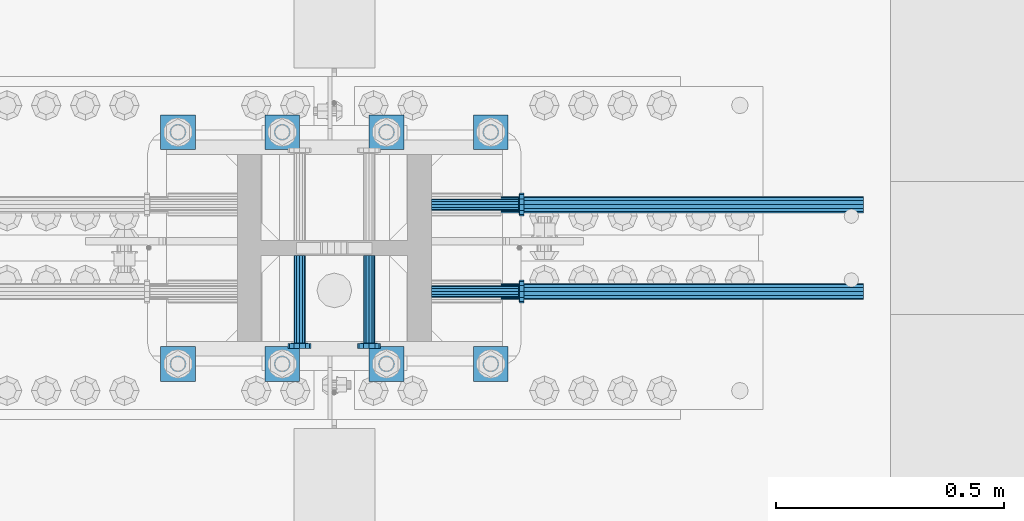
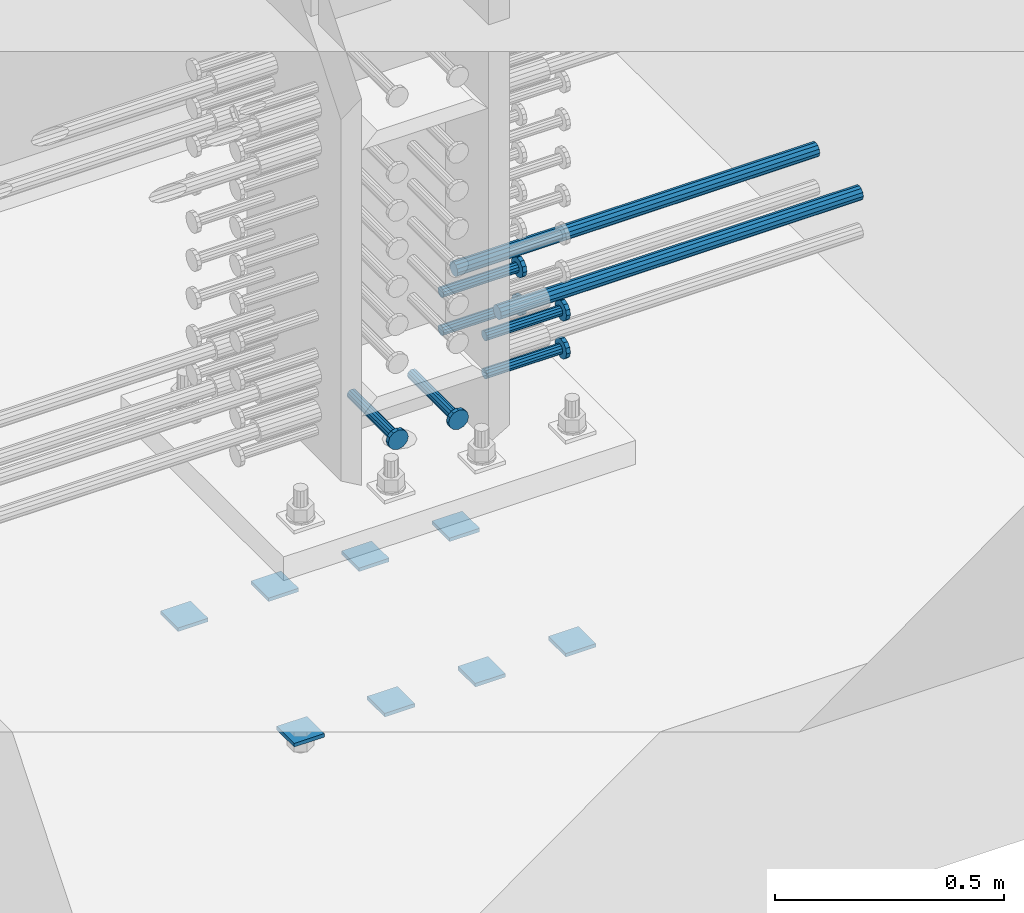
# One storey, part 1223 of 1763: 16 beams, 4 elements without a shape of their own.
"""IFC2X3 building model written with IfcOpenShell, lengths in millimetres."""

from ifc_helpers import new_model, si_unit, frame, origin_with_axes, place, context, subcontext, project, spatial, faceted_brep, material, type_object, element, aggregate, save


model = new_model("IFC2X3")

# Units and contexts
model_context = context("Model", 3, precision=1e-05, world=origin_with_axes())
body_context = subcontext(model_context, "Body", "Model", "MODEL_VIEW")
ifc_project = project(units=[si_unit("LENGTHUNIT", "METRE", prefix="MILLI"), si_unit("AREAUNIT", "SQUARE_METRE"), si_unit("VOLUMEUNIT", "CUBIC_METRE"), si_unit("MASSUNIT", "GRAM", prefix="KILO"), si_unit("TIMEUNIT", "SECOND"), si_unit("PLANEANGLEUNIT", "RADIAN"), si_unit("SOLIDANGLEUNIT", "STERADIAN"), si_unit("THERMODYNAMICTEMPERATUREUNIT", "DEGREE_CELSIUS"), si_unit("LUMINOUSINTENSITYUNIT", "LUMEN")], contexts=[model_context])

# Site, building, storey
site_placement = place(None, origin_with_axes())
site = spatial("IfcSite", under=ifc_project, at=site_placement, CompositionType="ELEMENT")
building_placement = place(site_placement, origin_with_axes())
building = spatial("IfcBuilding", under=site, at=building_placement, Name="Undefined", CompositionType="ELEMENT")
storey_placement = place(building_placement, origin_with_axes())
storey = spatial("IfcBuildingStorey", under=building, at=storey_placement, Name="Undefined", CompositionType="ELEMENT", Elevation=0.0)

# Assembly, beams
assembly_1_placement = place(storey_placement, origin_with_axes())
assembly_1 = element("IfcElementAssembly", 1, at=assembly_1_placement, inside=storey, Name="TEMPLATE", AssemblyPlace="NOTDEFINED", PredefinedType="RIGID_FRAME")
ifc_material_1 = material(Name="STEEL/A36")
beam_type_1 = type_object("IfcBeamType", PredefinedType="NOTDEFINED")
beam_1_placement = place(assembly_1_placement, frame((-61213.4372736986, 203.200000000006, 3348.0375), z_axis=(0.0, 1.0, 0.0), x_axis=(-1.0, 0.0, 0.0)))
beam_1 = element("IfcBeam", 2, at=beam_1_placement, type_object=beam_type_1, material=ifc_material_1, Name="WASHER PLATE", context=body_context, shape_type="Brep", body=[
    faceted_brep([(0.0, 4.76249999999709, -38.1000000000004), (0.0, 4.76249999999709, 38.1000000000004), (76.2000000000007, 4.76249999999982, 38.0999999999985), (76.2000000000007, 4.76249999999982, -38.0999999999985), (0.0, -4.76249999999709, 38.1000000000004), (76.2000000000007, -4.76249999999982, 38.0999999999985), (0.0, -4.76249999999709, -38.1000000000004), (76.2000000000007, -4.76249999999982, -38.0999999999985)], [[[0, 1, 2, 3]], [[1, 4, 5, 2]], [[4, 6, 7, 5]], [[6, 0, 3, 7]], [[5, 7, 3, 2]], [[6, 4, 1, 0]]]),
])
beam_2_placement = place(assembly_1_placement, frame((-61213.4372736986, 711.200000000006, 3348.0375), z_axis=(0.0, 1.0, 0.0), x_axis=(-1.0, 0.0, 0.0)))
beam_2 = element("IfcBeam", 3, at=beam_2_placement, type_object=beam_type_1, material=ifc_material_1, Name="WASHER PLATE", context=body_context, shape_type="Brep", body=[
    faceted_brep([(0.0, 4.76249999999709, -38.1000000000004), (0.0, 4.76249999999709, 38.1000000000004), (76.2000000000007, 4.76249999999982, 38.0999999999985), (76.2000000000007, 4.76249999999982, -38.0999999999985), (0.0, -4.76249999999709, 38.1000000000004), (76.2000000000007, -4.76249999999982, 38.0999999999985), (0.0, -4.76249999999709, -38.1000000000004), (76.2000000000007, -4.76249999999982, -38.0999999999985)], [[[0, 1, 2, 3]], [[1, 4, 5, 2]], [[4, 6, 7, 5]], [[6, 0, 3, 7]], [[5, 7, 3, 2]], [[6, 4, 1, 0]]]),
])
beam_3_placement = place(assembly_1_placement, frame((-61442.0372736986, 203.200000000006, 3348.0375), z_axis=(0.0, 1.0, 0.0), x_axis=(-1.0, 0.0, 0.0)))
beam_3 = element("IfcBeam", 4, at=beam_3_placement, type_object=beam_type_1, material=ifc_material_1, Name="WASHER PLATE", context=body_context, shape_type="Brep", body=[
    faceted_brep([(0.0, 4.76249999999709, -38.1000000000004), (0.0, 4.76249999999709, 38.1000000000004), (76.2000000000007, 4.76249999999982, 38.0999999999985), (76.2000000000007, 4.76249999999982, -38.0999999999985), (0.0, -4.76249999999709, 38.1000000000004), (76.2000000000007, -4.76249999999982, 38.0999999999985), (0.0, -4.76249999999709, -38.1000000000004), (76.2000000000007, -4.76249999999982, -38.0999999999985)], [[[0, 1, 2, 3]], [[1, 4, 5, 2]], [[4, 6, 7, 5]], [[6, 0, 3, 7]], [[5, 7, 3, 2]], [[6, 4, 1, 0]]]),
])
beam_4_placement = place(assembly_1_placement, frame((-61442.0372736986, 711.200000000006, 3348.0375), z_axis=(0.0, 1.0, 0.0), x_axis=(-1.0, 0.0, 0.0)))
beam_4 = element("IfcBeam", 5, at=beam_4_placement, type_object=beam_type_1, material=ifc_material_1, Name="WASHER PLATE", context=body_context, shape_type="Brep", body=[
    faceted_brep([(0.0, 4.76249999999709, -38.1000000000004), (0.0, 4.76249999999709, 38.1000000000004), (76.2000000000007, 4.76249999999982, 38.0999999999985), (76.2000000000007, 4.76249999999982, -38.0999999999985), (0.0, -4.76249999999709, 38.1000000000004), (76.2000000000007, -4.76249999999982, 38.0999999999985), (0.0, -4.76249999999709, -38.1000000000004), (76.2000000000007, -4.76249999999982, -38.0999999999985)], [[[0, 1, 2, 3]], [[1, 4, 5, 2]], [[4, 6, 7, 5]], [[6, 0, 3, 7]], [[5, 7, 3, 2]], [[6, 4, 1, 0]]]),
])
beam_5_placement = place(assembly_1_placement, frame((-61670.6372736986, 203.200000000006, 3348.0375), z_axis=(0.0, 1.0, 0.0), x_axis=(-1.0, 0.0, 0.0)))
beam_5 = element("IfcBeam", 6, at=beam_5_placement, type_object=beam_type_1, material=ifc_material_1, Name="WASHER PLATE", context=body_context, shape_type="Brep", body=[
    faceted_brep([(0.0, 4.76249999999709, -38.1000000000004), (0.0, 4.76249999999709, 38.1000000000004), (76.2000000000007, 4.76249999999982, 38.0999999999985), (76.2000000000007, 4.76249999999982, -38.0999999999985), (0.0, -4.76249999999709, 38.1000000000004), (76.2000000000007, -4.76249999999982, 38.0999999999985), (0.0, -4.76249999999709, -38.1000000000004), (76.2000000000007, -4.76249999999982, -38.0999999999985)], [[[0, 1, 2, 3]], [[1, 4, 5, 2]], [[4, 6, 7, 5]], [[6, 0, 3, 7]], [[5, 7, 3, 2]], [[6, 4, 1, 0]]]),
])
beam_6_placement = place(assembly_1_placement, frame((-61670.6372736986, 711.200000000006, 3348.0375), z_axis=(0.0, 1.0, 0.0), x_axis=(-1.0, 0.0, 0.0)))
beam_6 = element("IfcBeam", 7, at=beam_6_placement, type_object=beam_type_1, material=ifc_material_1, Name="WASHER PLATE", context=body_context, shape_type="Brep", body=[
    faceted_brep([(0.0, 4.76249999999709, -38.1000000000004), (0.0, 4.76249999999709, 38.1000000000004), (76.2000000000007, 4.76249999999982, 38.0999999999985), (76.2000000000007, 4.76249999999982, -38.0999999999985), (0.0, -4.76249999999709, 38.1000000000004), (76.2000000000007, -4.76249999999982, 38.0999999999985), (0.0, -4.76249999999709, -38.1000000000004), (76.2000000000007, -4.76249999999982, -38.0999999999985)], [[[0, 1, 2, 3]], [[1, 4, 5, 2]], [[4, 6, 7, 5]], [[6, 0, 3, 7]], [[5, 7, 3, 2]], [[6, 4, 1, 0]]]),
])
beam_7_placement = place(assembly_1_placement, frame((-61899.2372736986, 203.200000000006, 3348.0375), z_axis=(0.0, 1.0, 0.0), x_axis=(-1.0, 0.0, 0.0)))
beam_7 = element("IfcBeam", 8, at=beam_7_placement, type_object=beam_type_1, material=ifc_material_1, Name="WASHER PLATE", context=body_context, shape_type="Brep", body=[
    faceted_brep([(0.0, 4.76249999999709, -38.1000000000004), (0.0, 4.76249999999709, 38.1000000000004), (76.2000000000007, 4.76249999999982, 38.0999999999985), (76.2000000000007, 4.76249999999982, -38.0999999999985), (0.0, -4.76249999999709, 38.1000000000004), (76.2000000000007, -4.76249999999982, 38.0999999999985), (0.0, -4.76249999999709, -38.1000000000004), (76.2000000000007, -4.76249999999982, -38.0999999999985)], [[[0, 1, 2, 3]], [[1, 4, 5, 2]], [[4, 6, 7, 5]], [[6, 0, 3, 7]], [[5, 7, 3, 2]], [[6, 4, 1, 0]]]),
])
beam_8_placement = place(assembly_1_placement, frame((-61899.2372736986, 711.200000000006, 3348.0375), z_axis=(0.0, 1.0, 0.0), x_axis=(-1.0, 0.0, 0.0)))
beam_8 = element("IfcBeam", 9, at=beam_8_placement, type_object=beam_type_1, material=ifc_material_1, Name="WASHER PLATE", context=body_context, shape_type="Brep", body=[
    faceted_brep([(0.0, 4.76249999999709, -38.1000000000004), (0.0, 4.76249999999709, 38.1000000000004), (76.2000000000007, 4.76249999999982, 38.0999999999985), (76.2000000000007, 4.76249999999982, -38.0999999999985), (0.0, -4.76249999999709, 38.1000000000004), (76.2000000000007, -4.76249999999982, 38.0999999999985), (0.0, -4.76249999999709, -38.1000000000004), (76.2000000000007, -4.76249999999982, -38.0999999999985)], [[[0, 1, 2, 3]], [[1, 4, 5, 2]], [[4, 6, 7, 5]], [[6, 0, 3, 7]], [[5, 7, 3, 2]], [[6, 4, 1, 0]]]),
])
aggregate(assembly_1, [beam_1, beam_2, beam_3, beam_4, beam_5, beam_6, beam_7, beam_8])

# Assembly, beam
assembly_2_placement = place(storey_placement, origin_with_axes())
assembly_2 = element("IfcElementAssembly", 10, at=assembly_2_placement, inside=storey, Name="REBAR", AssemblyPlace="NOTDEFINED", PredefinedType="RIGID_FRAME")
ifc_material_2 = material(Name="STEEL/A706-GR.80")
beam_type_2 = type_object("IfcBeamType", Name="#11 REBAR", PredefinedType="NOTDEFINED")
beam_9_placement = place(assembly_2_placement, frame((-61348.946286658, 361.949999998906, 4165.60000000003), z_axis=(0.0, 0.0, 1.0), x_axis=(1.0, 0.0, 0.0)))
beam_9 = element("IfcBeam", 11, at=beam_9_placement, type_object=beam_type_2, material=ifc_material_2, Name="REBAR", ObjectType="#11 REBAR", context=body_context, shape_type="Brep", body=[
    faceted_brep([(0.0, -17.9069999999992, 0.0), (0.0, -15.507916905568, -8.95349999999962), (914.400000001086, -15.507916905568, -8.95349999999962), (914.400000001086, -17.9069999999992, 0.0), (0.0, -8.95349999999962, -15.507916905568), (914.400000001086, -8.95349999999962, -15.507916905568), (0.0, 0.0, -17.9070000000002), (914.400000001086, 0.0, -17.9070000000002), (0.0, 8.95349999999962, -15.507916905568), (914.400000001086, 8.95349999999962, -15.507916905568), (0.0, 15.507916905568, -8.95349999999962), (914.400000001086, 15.507916905568, -8.95349999999962), (0.0, 17.9069999999992, 0.0), (914.400000001086, 17.9069999999992, 0.0), (0.0, 15.507916905568, 8.95349999999962), (914.400000001086, 15.507916905568, 8.95349999999962), (0.0, 8.95349999999962, 15.507916905568), (914.400000001086, 8.95349999999962, 15.507916905568), (0.0, 0.0, 17.9070000000002), (914.400000001086, 0.0, 17.9070000000002), (0.0, -8.95349999999962, 15.507916905568), (914.400000001086, -8.95349999999962, 15.507916905568), (0.0, -15.507916905568, 8.95349999999962), (914.400000001086, -15.507916905568, 8.95349999999962)], [[[0, 1, 2, 3]], [[1, 4, 5, 2]], [[4, 6, 7, 5]], [[6, 8, 9, 7]], [[8, 10, 11, 9]], [[10, 12, 13, 11]], [[12, 14, 15, 13]], [[14, 16, 17, 15]], [[16, 18, 19, 17]], [[18, 20, 21, 19]], [[20, 22, 23, 21]], [[22, 0, 3, 23]], [[5, 7, 9, 11, 13, 15, 17, 19, 21, 23, 3, 2]], [[22, 20, 18, 16, 14, 12, 10, 8, 6, 4, 1, 0]]]),
])
aggregate(assembly_2, [beam_9])

assembly_3_placement = place(storey_placement, origin_with_axes())
assembly_3 = element("IfcElementAssembly", 12, at=assembly_3_placement, inside=storey, Name="REBAR", AssemblyPlace="NOTDEFINED", PredefinedType="RIGID_FRAME")
beam_10_placement = place(assembly_3_placement, frame((-61348.9462179955, 552.44999999832, 4165.60000000003), z_axis=(0.0, 0.0, 1.0), x_axis=(1.0, 0.0, 0.0)))
beam_10 = element("IfcBeam", 13, at=beam_10_placement, type_object=beam_type_2, material=ifc_material_2, Name="REBAR", ObjectType="#11 REBAR", context=body_context, shape_type="Brep", body=[
    faceted_brep([(0.0, -17.9069999999992, 0.0), (0.0, -15.507916905568, -8.95349999999962), (914.400000001086, -15.507916905568, -8.95349999999962), (914.400000001086, -17.9069999999992, 0.0), (0.0, -8.95349999999962, -15.507916905568), (914.400000001086, -8.95349999999962, -15.507916905568), (0.0, 0.0, -17.9070000000002), (914.400000001086, 0.0, -17.9070000000002), (0.0, 8.95349999999962, -15.507916905568), (914.400000001086, 8.95349999999962, -15.507916905568), (0.0, 15.507916905568, -8.95349999999962), (914.400000001086, 15.507916905568, -8.95349999999962), (0.0, 17.9069999999992, 0.0), (914.400000001086, 17.9069999999992, 0.0), (0.0, 15.507916905568, 8.95349999999962), (914.400000001086, 15.507916905568, 8.95349999999962), (0.0, 8.95349999999962, 15.507916905568), (914.400000001086, 8.95349999999962, 15.507916905568), (0.0, 0.0, 17.9070000000002), (914.400000001086, 0.0, 17.9070000000002), (0.0, -8.95349999999962, 15.507916905568), (914.400000001086, -8.95349999999962, 15.507916905568), (0.0, -15.507916905568, 8.95349999999962), (914.400000001086, -15.507916905568, 8.95349999999962)], [[[0, 1, 2, 3]], [[1, 4, 5, 2]], [[4, 6, 7, 5]], [[6, 8, 9, 7]], [[8, 10, 11, 9]], [[10, 12, 13, 11]], [[12, 14, 15, 13]], [[14, 16, 17, 15]], [[16, 18, 19, 17]], [[18, 20, 21, 19]], [[20, 22, 23, 21]], [[22, 0, 3, 23]], [[5, 7, 9, 11, 13, 15, 17, 19, 21, 23, 3, 2]], [[22, 20, 18, 16, 14, 12, 10, 8, 6, 4, 1, 0]]]),
])
aggregate(assembly_3, [beam_10])

# Assembly, beams
assembly_4_placement = place(storey_placement, origin_with_axes())
assembly_4 = element("IfcElementAssembly", 14, at=assembly_4_placement, inside=storey, Name="COLUMN", AssemblyPlace="NOTDEFINED", PredefinedType="RIGID_FRAME")
ifc_material_3 = material(Name="STEEL/A108")
beam_type_3 = type_object("IfcBeamType", PredefinedType="NOTDEFINED")
beam_11_placement = place(assembly_4_placement, frame((-61381.7123210203, 361.950000000609, 4114.80000000002), z_axis=(0.0, 1.0, 0.0), x_axis=(1.0, 0.0, 0.0)))
beam_11 = element("IfcBeam", 15, at=beam_11_placement, type_object=beam_type_3, material=ifc_material_3, Name="HEADED STUD ANCHOR", context=body_context, shape_type="Brep", body=[
    faceted_brep([(0.0, -12.6999999999971, -1.81898940354586e-12), (3.63797880709171e-12, -11.0, -6.34999990463257), (191.00799999576, -11.0, -6.34999990454889), (191.007999995752, -12.6999998092651, 8.36735125631094e-11), (7.27595761418343e-12, -6.34999990463257, -11.0), (191.00799999576, -6.34999990463257, -10.9999999999163), (3.63797880709171e-12, 0.0, -12.6999998092651), (191.00799999576, 0.0, -12.6999998091815), (7.27595761418343e-12, 6.34999990463257, -11.0), (191.00799999576, 6.34999990463257, -10.9999999999163), (3.63797880709171e-12, 11.0, -6.34999990463257), (191.00799999576, 11.0, -6.34999990454889), (0.0, 12.6999999999971, -1.81898940354586e-12), (191.007999995752, 12.6999998092651, 8.36735125631094e-11), (0.0, 11.0, 6.34999990463257), (191.007999995752, 11.0, 6.34999990471624), (-3.63797880709171e-12, 6.34999990463257, 11.0), (191.007999995749, 6.34999990463257, 11.0000000000837), (-3.63797880709171e-12, 0.0, 12.6999998092651), (191.007999995749, 0.0, 12.6999998093488), (-3.63797880709171e-12, -6.34999990463257, 11.0), (191.007999995749, -6.34999990463257, 11.0000000000837), (0.0, -11.0, 6.34999990463257), (191.007999995752, -11.0, 6.34999990471624), (193.039999995715, -22.0, -12.6999998091796), (193.039999995708, -25.3999996185303, 8.54925019666553e-11), (193.039999995719, -12.6999998092651, -21.9999999999145), (193.039999995719, 0.0, -25.3999996184448), (193.039999995719, 12.6999998092651, -21.9999999999145), (193.039999995715, 22.0, -12.6999998091796), (193.039999995708, 25.3999996185303, 8.54925019666553e-11), (193.039999995704, 22.0, 12.6999998093506), (193.039999995701, 12.6999998092651, 22.0000000000855), (193.039999995697, 0.0, 25.3999996186158), (193.039999995701, -12.6999998092651, 22.0000000000855), (193.039999995704, -22.0, 12.6999998093506), (203.199999995486, -22.0, -12.6999998091742), (203.199999995482, -25.3999996185303, 9.09494701772928e-11), (203.199999995493, -12.6999998092651, -21.9999999999091), (203.199999995493, 0.0, -25.3999996184393), (203.199999995493, 12.6999998092651, -21.9999999999091), (203.199999995486, 22.0, -12.6999998091742), (203.199999995482, 25.3999996185303, 9.09494701772928e-11), (203.199999995479, 22.0, 12.6999998093561), (203.199999995475, 12.6999998092651, 22.0000000000909), (203.199999995471, 0.0, 25.3999996186212), (203.199999995475, -12.6999998092651, 22.0000000000909), (203.199999995479, -22.0, 12.6999998093561)], [[[0, 1, 2, 3]], [[1, 4, 5, 2]], [[4, 6, 7, 5]], [[6, 8, 9, 7]], [[8, 10, 11, 9]], [[10, 12, 13, 11]], [[12, 14, 15, 13]], [[14, 16, 17, 15]], [[16, 18, 19, 17]], [[18, 20, 21, 19]], [[20, 22, 23, 21]], [[22, 0, 3, 23]], [[22, 20, 18, 16, 14, 12, 10, 8, 6, 4, 1, 0]], [[3, 2, 24, 25]], [[2, 5, 26, 24]], [[5, 7, 27, 26]], [[7, 9, 28, 27]], [[9, 11, 29, 28]], [[11, 13, 30, 29]], [[13, 15, 31, 30]], [[15, 17, 32, 31]], [[17, 19, 33, 32]], [[19, 21, 34, 33]], [[21, 23, 35, 34]], [[23, 3, 25, 35]], [[25, 24, 36, 37]], [[24, 26, 38, 36]], [[26, 27, 39, 38]], [[27, 28, 40, 39]], [[28, 29, 41, 40]], [[29, 30, 42, 41]], [[30, 31, 43, 42]], [[31, 32, 44, 43]], [[32, 33, 45, 44]], [[33, 34, 46, 45]], [[34, 35, 47, 46]], [[35, 25, 37, 47]], [[38, 39, 40, 41, 42, 43, 44, 45, 46, 47, 37, 36]]]),
])
beam_12_placement = place(assembly_4_placement, frame((-61381.7122523598, 552.449999999998, 4114.80000000002), z_axis=(0.0, 1.0, 0.0), x_axis=(1.0, 0.0, 0.0)))
beam_12 = element("IfcBeam", 16, at=beam_12_placement, type_object=beam_type_3, material=ifc_material_3, Name="HEADED STUD ANCHOR", context=body_context, shape_type="Brep", body=[
    faceted_brep([(0.0, -12.6999999999971, -1.81898940354586e-12), (3.63797880709171e-12, -11.0, -6.34999990463257), (191.00799999576, -11.0, -6.34999990454889), (191.007999995752, -12.6999998092651, 8.36735125631094e-11), (7.27595761418343e-12, -6.34999990463257, -11.0), (191.00799999576, -6.34999990463257, -10.9999999999163), (3.63797880709171e-12, 0.0, -12.6999998092651), (191.00799999576, 0.0, -12.6999998091815), (7.27595761418343e-12, 6.34999990463257, -11.0), (191.00799999576, 6.34999990463257, -10.9999999999163), (3.63797880709171e-12, 11.0, -6.34999990463257), (191.00799999576, 11.0, -6.34999990454889), (0.0, 12.6999999999971, -1.81898940354586e-12), (191.007999995752, 12.6999998092651, 8.36735125631094e-11), (0.0, 11.0, 6.34999990463257), (191.007999995752, 11.0, 6.34999990471624), (-3.63797880709171e-12, 6.34999990463257, 11.0), (191.007999995749, 6.34999990463257, 11.0000000000837), (-3.63797880709171e-12, 0.0, 12.6999998092651), (191.007999995749, 0.0, 12.6999998093488), (-3.63797880709171e-12, -6.34999990463257, 11.0), (191.007999995749, -6.34999990463257, 11.0000000000837), (0.0, -11.0, 6.34999990463257), (191.007999995752, -11.0, 6.34999990471624), (193.039999995715, -22.0, -12.6999998091796), (193.039999995708, -25.3999996185303, 8.54925019666553e-11), (193.039999995719, -12.6999998092651, -21.9999999999145), (193.039999995719, 0.0, -25.3999996184448), (193.039999995719, 12.6999998092651, -21.9999999999145), (193.039999995715, 22.0, -12.6999998091796), (193.039999995708, 25.3999996185303, 8.54925019666553e-11), (193.039999995704, 22.0, 12.6999998093506), (193.039999995701, 12.6999998092651, 22.0000000000855), (193.039999995697, 0.0, 25.3999996186158), (193.039999995701, -12.6999998092651, 22.0000000000855), (193.039999995704, -22.0, 12.6999998093506), (203.199999995486, -22.0, -12.6999998091742), (203.199999995482, -25.3999996185303, 9.09494701772928e-11), (203.199999995493, -12.6999998092651, -21.9999999999091), (203.199999995493, 0.0, -25.3999996184393), (203.199999995493, 12.6999998092651, -21.9999999999091), (203.199999995486, 22.0, -12.6999998091742), (203.199999995482, 25.3999996185303, 9.09494701772928e-11), (203.199999995479, 22.0, 12.6999998093561), (203.199999995475, 12.6999998092651, 22.0000000000909), (203.199999995471, 0.0, 25.3999996186212), (203.199999995475, -12.6999998092651, 22.0000000000909), (203.199999995479, -22.0, 12.6999998093561)], [[[0, 1, 2, 3]], [[1, 4, 5, 2]], [[4, 6, 7, 5]], [[6, 8, 9, 7]], [[8, 10, 11, 9]], [[10, 12, 13, 11]], [[12, 14, 15, 13]], [[14, 16, 17, 15]], [[16, 18, 19, 17]], [[18, 20, 21, 19]], [[20, 22, 23, 21]], [[22, 0, 3, 23]], [[22, 20, 18, 16, 14, 12, 10, 8, 6, 4, 1, 0]], [[3, 2, 24, 25]], [[2, 5, 26, 24]], [[5, 7, 27, 26]], [[7, 9, 28, 27]], [[9, 11, 29, 28]], [[11, 13, 30, 29]], [[13, 15, 31, 30]], [[15, 17, 32, 31]], [[17, 19, 33, 32]], [[19, 21, 34, 33]], [[21, 23, 35, 34]], [[23, 3, 25, 35]], [[25, 24, 36, 37]], [[24, 26, 38, 36]], [[26, 27, 39, 38]], [[27, 28, 40, 39]], [[28, 29, 41, 40]], [[29, 30, 42, 41]], [[30, 31, 43, 42]], [[31, 32, 44, 43]], [[32, 33, 45, 44]], [[33, 34, 46, 45]], [[34, 35, 47, 46]], [[35, 25, 37, 47]], [[38, 39, 40, 41, 42, 43, 44, 45, 46, 47, 37, 36]]]),
])
beam_13_placement = place(assembly_4_placement, frame((-61670.6372733567, 440.53099988573, 4013.2), z_axis=(1.0, 0.0, 0.0), x_axis=(0.0, -1.0, 0.0)))
beam_13 = element("IfcBeam", 17, at=beam_13_placement, type_object=beam_type_3, material=ifc_material_3, Name="HEADED STUD ANCHOR", context=body_context, shape_type="Brep", body=[
    faceted_brep([(0.0, -12.6999999999971, -1.81898940354586e-12), (3.63797880709171e-12, -11.0, -6.34999990463257), (191.00799999576, -11.0, -6.34999990454889), (191.007999995752, -12.6999998092651, 8.36735125631094e-11), (7.27595761418343e-12, -6.34999990463257, -11.0), (191.00799999576, -6.34999990463257, -10.9999999999163), (3.63797880709171e-12, 0.0, -12.6999998092651), (191.00799999576, 0.0, -12.6999998091815), (7.27595761418343e-12, 6.34999990463257, -11.0), (191.00799999576, 6.34999990463257, -10.9999999999163), (3.63797880709171e-12, 11.0, -6.34999990463257), (191.00799999576, 11.0, -6.34999990454889), (0.0, 12.6999999999971, -1.81898940354586e-12), (191.007999995752, 12.6999998092651, 8.36735125631094e-11), (0.0, 11.0, 6.34999990463257), (191.007999995752, 11.0, 6.34999990471624), (-3.63797880709171e-12, 6.34999990463257, 11.0), (191.007999995749, 6.34999990463257, 11.0000000000837), (-3.63797880709171e-12, 0.0, 12.6999998092651), (191.007999995749, 0.0, 12.6999998093488), (-3.63797880709171e-12, -6.34999990463257, 11.0), (191.007999995749, -6.34999990463257, 11.0000000000837), (0.0, -11.0, 6.34999990463257), (191.007999995752, -11.0, 6.34999990471624), (193.039999995715, -22.0, -12.6999998091796), (193.039999995708, -25.3999996185303, 8.54925019666553e-11), (193.039999995719, -12.6999998092651, -21.9999999999145), (193.039999995719, 0.0, -25.3999996184448), (193.039999995719, 12.6999998092651, -21.9999999999145), (193.039999995715, 22.0, -12.6999998091796), (193.039999995708, 25.3999996185303, 8.54925019666553e-11), (193.039999995704, 22.0, 12.6999998093506), (193.039999995701, 12.6999998092651, 22.0000000000855), (193.039999995697, 0.0, 25.3999996186158), (193.039999995701, -12.6999998092651, 22.0000000000855), (193.039999995704, -22.0, 12.6999998093506), (203.199999995486, -22.0, -12.6999998091742), (203.199999995482, -25.3999996185303, 9.09494701772928e-11), (203.199999995493, -12.6999998092651, -21.9999999999091), (203.199999995493, 0.0, -25.3999996184393), (203.199999995493, 12.6999998092651, -21.9999999999091), (203.199999995486, 22.0, -12.6999998091742), (203.199999995482, 25.3999996185303, 9.09494701772928e-11), (203.199999995479, 22.0, 12.6999998093561), (203.199999995475, 12.6999998092651, 22.0000000000909), (203.199999995471, 0.0, 25.3999996186212), (203.199999995475, -12.6999998092651, 22.0000000000909), (203.199999995479, -22.0, 12.6999998093561)], [[[0, 1, 2, 3]], [[1, 4, 5, 2]], [[4, 6, 7, 5]], [[6, 8, 9, 7]], [[8, 10, 11, 9]], [[10, 12, 13, 11]], [[12, 14, 15, 13]], [[14, 16, 17, 15]], [[16, 18, 19, 17]], [[18, 20, 21, 19]], [[20, 22, 23, 21]], [[22, 0, 3, 23]], [[22, 20, 18, 16, 14, 12, 10, 8, 6, 4, 1, 0]], [[3, 2, 24, 25]], [[2, 5, 26, 24]], [[5, 7, 27, 26]], [[7, 9, 28, 27]], [[9, 11, 29, 28]], [[11, 13, 30, 29]], [[13, 15, 31, 30]], [[15, 17, 32, 31]], [[17, 19, 33, 32]], [[19, 21, 34, 33]], [[21, 23, 35, 34]], [[23, 3, 25, 35]], [[25, 24, 36, 37]], [[24, 26, 38, 36]], [[26, 27, 39, 38]], [[27, 28, 40, 39]], [[28, 29, 41, 40]], [[29, 30, 42, 41]], [[30, 31, 43, 42]], [[31, 32, 44, 43]], [[32, 33, 45, 44]], [[33, 34, 46, 45]], [[34, 35, 47, 46]], [[35, 25, 37, 47]], [[38, 39, 40, 41, 42, 43, 44, 45, 46, 47, 37, 36]]]),
])
beam_14_placement = place(assembly_4_placement, frame((-61518.2372733576, 440.531000000006, 4013.2), z_axis=(1.0, 0.0, 0.0), x_axis=(0.0, -1.0, 0.0)))
beam_14 = element("IfcBeam", 18, at=beam_14_placement, type_object=beam_type_3, material=ifc_material_3, Name="HEADED STUD ANCHOR", context=body_context, shape_type="Brep", body=[
    faceted_brep([(0.0, -12.6999999999971, -1.81898940354586e-12), (3.63797880709171e-12, -11.0, -6.34999990463257), (191.00799999576, -11.0, -6.34999990454889), (191.007999995752, -12.6999998092651, 8.36735125631094e-11), (7.27595761418343e-12, -6.34999990463257, -11.0), (191.00799999576, -6.34999990463257, -10.9999999999163), (3.63797880709171e-12, 0.0, -12.6999998092651), (191.00799999576, 0.0, -12.6999998091815), (7.27595761418343e-12, 6.34999990463257, -11.0), (191.00799999576, 6.34999990463257, -10.9999999999163), (3.63797880709171e-12, 11.0, -6.34999990463257), (191.00799999576, 11.0, -6.34999990454889), (0.0, 12.6999999999971, -1.81898940354586e-12), (191.007999995752, 12.6999998092651, 8.36735125631094e-11), (0.0, 11.0, 6.34999990463257), (191.007999995752, 11.0, 6.34999990471624), (-3.63797880709171e-12, 6.34999990463257, 11.0), (191.007999995749, 6.34999990463257, 11.0000000000837), (-3.63797880709171e-12, 0.0, 12.6999998092651), (191.007999995749, 0.0, 12.6999998093488), (-3.63797880709171e-12, -6.34999990463257, 11.0), (191.007999995749, -6.34999990463257, 11.0000000000837), (0.0, -11.0, 6.34999990463257), (191.007999995752, -11.0, 6.34999990471624), (193.039999995715, -22.0, -12.6999998091796), (193.039999995708, -25.3999996185303, 8.54925019666553e-11), (193.039999995719, -12.6999998092651, -21.9999999999145), (193.039999995719, 0.0, -25.3999996184448), (193.039999995719, 12.6999998092651, -21.9999999999145), (193.039999995715, 22.0, -12.6999998091796), (193.039999995708, 25.3999996185303, 8.54925019666553e-11), (193.039999995704, 22.0, 12.6999998093506), (193.039999995701, 12.6999998092651, 22.0000000000855), (193.039999995697, 0.0, 25.3999996186158), (193.039999995701, -12.6999998092651, 22.0000000000855), (193.039999995704, -22.0, 12.6999998093506), (203.199999995486, -22.0, -12.6999998091742), (203.199999995482, -25.3999996185303, 9.09494701772928e-11), (203.199999995493, -12.6999998092651, -21.9999999999091), (203.199999995493, 0.0, -25.3999996184393), (203.199999995493, 12.6999998092651, -21.9999999999091), (203.199999995486, 22.0, -12.6999998091742), (203.199999995482, 25.3999996185303, 9.09494701772928e-11), (203.199999995479, 22.0, 12.6999998093561), (203.199999995475, 12.6999998092651, 22.0000000000909), (203.199999995471, 0.0, 25.3999996186212), (203.199999995475, -12.6999998092651, 22.0000000000909), (203.199999995479, -22.0, 12.6999998093561)], [[[0, 1, 2, 3]], [[1, 4, 5, 2]], [[4, 6, 7, 5]], [[6, 8, 9, 7]], [[8, 10, 11, 9]], [[10, 12, 13, 11]], [[12, 14, 15, 13]], [[14, 16, 17, 15]], [[16, 18, 19, 17]], [[18, 20, 21, 19]], [[20, 22, 23, 21]], [[22, 0, 3, 23]], [[22, 20, 18, 16, 14, 12, 10, 8, 6, 4, 1, 0]], [[3, 2, 24, 25]], [[2, 5, 26, 24]], [[5, 7, 27, 26]], [[7, 9, 28, 27]], [[9, 11, 29, 28]], [[11, 13, 30, 29]], [[13, 15, 31, 30]], [[15, 17, 32, 31]], [[17, 19, 33, 32]], [[19, 21, 34, 33]], [[21, 23, 35, 34]], [[23, 3, 25, 35]], [[25, 24, 36, 37]], [[24, 26, 38, 36]], [[26, 27, 39, 38]], [[27, 28, 40, 39]], [[28, 29, 41, 40]], [[29, 30, 42, 41]], [[30, 31, 43, 42]], [[31, 32, 44, 43]], [[32, 33, 45, 44]], [[33, 34, 46, 45]], [[34, 35, 47, 46]], [[35, 25, 37, 47]], [[38, 39, 40, 41, 42, 43, 44, 45, 46, 47, 37, 36]]]),
])
beam_15_placement = place(assembly_4_placement, frame((-61381.7122522853, 361.950000000609, 4013.2), z_axis=(0.0, 1.0, 0.0), x_axis=(1.0, 0.0, 0.0)))
beam_15 = element("IfcBeam", 19, at=beam_15_placement, type_object=beam_type_3, material=ifc_material_3, Name="HEADED STUD ANCHOR", context=body_context, shape_type="Brep", body=[
    faceted_brep([(0.0, -12.6999999999971, -1.81898940354586e-12), (3.63797880709171e-12, -11.0, -6.34999990463257), (191.00799999576, -11.0, -6.34999990454889), (191.007999995752, -12.6999998092651, 8.36735125631094e-11), (7.27595761418343e-12, -6.34999990463257, -11.0), (191.00799999576, -6.34999990463257, -10.9999999999163), (3.63797880709171e-12, 0.0, -12.6999998092651), (191.00799999576, 0.0, -12.6999998091815), (7.27595761418343e-12, 6.34999990463257, -11.0), (191.00799999576, 6.34999990463257, -10.9999999999163), (3.63797880709171e-12, 11.0, -6.34999990463257), (191.00799999576, 11.0, -6.34999990454889), (0.0, 12.6999999999971, -1.81898940354586e-12), (191.007999995752, 12.6999998092651, 8.36735125631094e-11), (0.0, 11.0, 6.34999990463257), (191.007999995752, 11.0, 6.34999990471624), (-3.63797880709171e-12, 6.34999990463257, 11.0), (191.007999995749, 6.34999990463257, 11.0000000000837), (-3.63797880709171e-12, 0.0, 12.6999998092651), (191.007999995749, 0.0, 12.6999998093488), (-3.63797880709171e-12, -6.34999990463257, 11.0), (191.007999995749, -6.34999990463257, 11.0000000000837), (0.0, -11.0, 6.34999990463257), (191.007999995752, -11.0, 6.34999990471624), (193.039999995715, -22.0, -12.6999998091796), (193.039999995708, -25.3999996185303, 8.54925019666553e-11), (193.039999995719, -12.6999998092651, -21.9999999999145), (193.039999995719, 0.0, -25.3999996184448), (193.039999995719, 12.6999998092651, -21.9999999999145), (193.039999995715, 22.0, -12.6999998091796), (193.039999995708, 25.3999996185303, 8.54925019666553e-11), (193.039999995704, 22.0, 12.6999998093506), (193.039999995701, 12.6999998092651, 22.0000000000855), (193.039999995697, 0.0, 25.3999996186158), (193.039999995701, -12.6999998092651, 22.0000000000855), (193.039999995704, -22.0, 12.6999998093506), (203.199999995486, -22.0, -12.6999998091742), (203.199999995482, -25.3999996185303, 9.09494701772928e-11), (203.199999995493, -12.6999998092651, -21.9999999999091), (203.199999995493, 0.0, -25.3999996184393), (203.199999995493, 12.6999998092651, -21.9999999999091), (203.199999995486, 22.0, -12.6999998091742), (203.199999995482, 25.3999996185303, 9.09494701772928e-11), (203.199999995479, 22.0, 12.6999998093561), (203.199999995475, 12.6999998092651, 22.0000000000909), (203.199999995471, 0.0, 25.3999996186212), (203.199999995475, -12.6999998092651, 22.0000000000909), (203.199999995479, -22.0, 12.6999998093561)], [[[0, 1, 2, 3]], [[1, 4, 5, 2]], [[4, 6, 7, 5]], [[6, 8, 9, 7]], [[8, 10, 11, 9]], [[10, 12, 13, 11]], [[12, 14, 15, 13]], [[14, 16, 17, 15]], [[16, 18, 19, 17]], [[18, 20, 21, 19]], [[20, 22, 23, 21]], [[22, 0, 3, 23]], [[22, 20, 18, 16, 14, 12, 10, 8, 6, 4, 1, 0]], [[3, 2, 24, 25]], [[2, 5, 26, 24]], [[5, 7, 27, 26]], [[7, 9, 28, 27]], [[9, 11, 29, 28]], [[11, 13, 30, 29]], [[13, 15, 31, 30]], [[15, 17, 32, 31]], [[17, 19, 33, 32]], [[19, 21, 34, 33]], [[21, 23, 35, 34]], [[23, 3, 25, 35]], [[25, 24, 36, 37]], [[24, 26, 38, 36]], [[26, 27, 39, 38]], [[27, 28, 40, 39]], [[28, 29, 41, 40]], [[29, 30, 42, 41]], [[30, 31, 43, 42]], [[31, 32, 44, 43]], [[32, 33, 45, 44]], [[33, 34, 46, 45]], [[34, 35, 47, 46]], [[35, 25, 37, 47]], [[38, 39, 40, 41, 42, 43, 44, 45, 46, 47, 37, 36]]]),
])
beam_16_placement = place(assembly_4_placement, frame((-61381.7121836248, 552.449999999998, 4013.2), z_axis=(0.0, 1.0, 0.0), x_axis=(1.0, 0.0, 0.0)))
beam_16 = element("IfcBeam", 20, at=beam_16_placement, type_object=beam_type_3, material=ifc_material_3, Name="HEADED STUD ANCHOR", context=body_context, shape_type="Brep", body=[
    faceted_brep([(0.0, -12.6999999999971, -1.81898940354586e-12), (3.63797880709171e-12, -11.0, -6.34999990463257), (191.00799999576, -11.0, -6.34999990454889), (191.007999995752, -12.6999998092651, 8.36735125631094e-11), (7.27595761418343e-12, -6.34999990463257, -11.0), (191.00799999576, -6.34999990463257, -10.9999999999163), (3.63797880709171e-12, 0.0, -12.6999998092651), (191.00799999576, 0.0, -12.6999998091815), (7.27595761418343e-12, 6.34999990463257, -11.0), (191.00799999576, 6.34999990463257, -10.9999999999163), (3.63797880709171e-12, 11.0, -6.34999990463257), (191.00799999576, 11.0, -6.34999990454889), (0.0, 12.6999999999971, -1.81898940354586e-12), (191.007999995752, 12.6999998092651, 8.36735125631094e-11), (0.0, 11.0, 6.34999990463257), (191.007999995752, 11.0, 6.34999990471624), (-3.63797880709171e-12, 6.34999990463257, 11.0), (191.007999995749, 6.34999990463257, 11.0000000000837), (-3.63797880709171e-12, 0.0, 12.6999998092651), (191.007999995749, 0.0, 12.6999998093488), (-3.63797880709171e-12, -6.34999990463257, 11.0), (191.007999995749, -6.34999990463257, 11.0000000000837), (0.0, -11.0, 6.34999990463257), (191.007999995752, -11.0, 6.34999990471624), (193.039999995715, -22.0, -12.6999998091796), (193.039999995708, -25.3999996185303, 8.54925019666553e-11), (193.039999995719, -12.6999998092651, -21.9999999999145), (193.039999995719, 0.0, -25.3999996184448), (193.039999995719, 12.6999998092651, -21.9999999999145), (193.039999995715, 22.0, -12.6999998091796), (193.039999995708, 25.3999996185303, 8.54925019666553e-11), (193.039999995704, 22.0, 12.6999998093506), (193.039999995701, 12.6999998092651, 22.0000000000855), (193.039999995697, 0.0, 25.3999996186158), (193.039999995701, -12.6999998092651, 22.0000000000855), (193.039999995704, -22.0, 12.6999998093506), (203.199999995486, -22.0, -12.6999998091742), (203.199999995482, -25.3999996185303, 9.09494701772928e-11), (203.199999995493, -12.6999998092651, -21.9999999999091), (203.199999995493, 0.0, -25.3999996184393), (203.199999995493, 12.6999998092651, -21.9999999999091), (203.199999995486, 22.0, -12.6999998091742), (203.199999995482, 25.3999996185303, 9.09494701772928e-11), (203.199999995479, 22.0, 12.6999998093561), (203.199999995475, 12.6999998092651, 22.0000000000909), (203.199999995471, 0.0, 25.3999996186212), (203.199999995475, -12.6999998092651, 22.0000000000909), (203.199999995479, -22.0, 12.6999998093561)], [[[0, 1, 2, 3]], [[1, 4, 5, 2]], [[4, 6, 7, 5]], [[6, 8, 9, 7]], [[8, 10, 11, 9]], [[10, 12, 13, 11]], [[12, 14, 15, 13]], [[14, 16, 17, 15]], [[16, 18, 19, 17]], [[18, 20, 21, 19]], [[20, 22, 23, 21]], [[22, 0, 3, 23]], [[22, 20, 18, 16, 14, 12, 10, 8, 6, 4, 1, 0]], [[3, 2, 24, 25]], [[2, 5, 26, 24]], [[5, 7, 27, 26]], [[7, 9, 28, 27]], [[9, 11, 29, 28]], [[11, 13, 30, 29]], [[13, 15, 31, 30]], [[15, 17, 32, 31]], [[17, 19, 33, 32]], [[19, 21, 34, 33]], [[21, 23, 35, 34]], [[23, 3, 25, 35]], [[25, 24, 36, 37]], [[24, 26, 38, 36]], [[26, 27, 39, 38]], [[27, 28, 40, 39]], [[28, 29, 41, 40]], [[29, 30, 42, 41]], [[30, 31, 43, 42]], [[31, 32, 44, 43]], [[32, 33, 45, 44]], [[33, 34, 46, 45]], [[34, 35, 47, 46]], [[35, 25, 37, 47]], [[38, 39, 40, 41, 42, 43, 44, 45, 46, 47, 37, 36]]]),
])
aggregate(assembly_4, [beam_11, beam_12, beam_13, beam_14, beam_15, beam_16])

save(model, "model.ifc")
